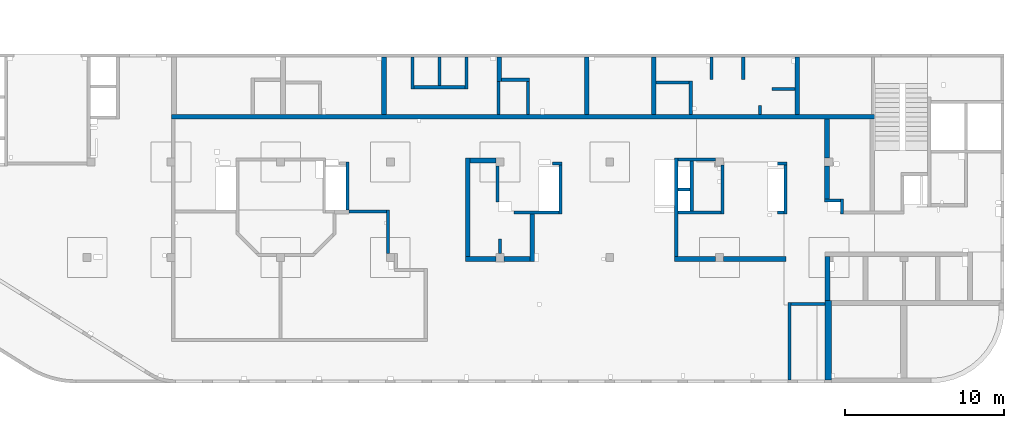
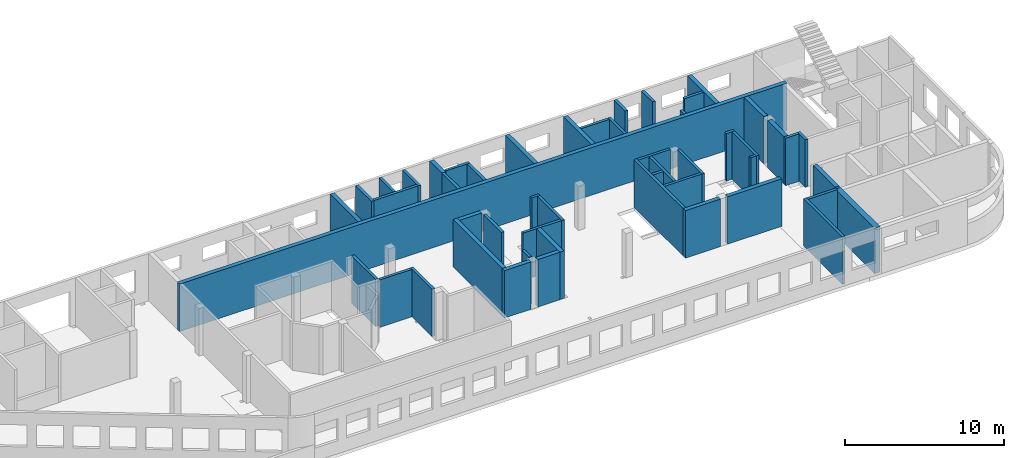
# One storey, part 4 of 10: 51 walls.
"""IFC4 building model written with IfcOpenShell, lengths in millimetres."""

from ifc_helpers import new_model, entity, si_unit, converted_unit, derived_unit, direction, frame, origin, place, context, subcontext, project, spatial, indexed_curve, outline, extrude, material, type_object, element, save


model = new_model("IFC4")

# Units and contexts
model_context = context("Model", 3, precision=0.01, world=origin(), true_north=direction((6.12303176911189e-17, 1.0)))
plan_context = context("Plan", 3, precision=0.01, world=origin(), true_north=direction((6.12303176911189e-17, 1.0)))
body_context = subcontext(model_context, "Body", "Model", "MODEL_VIEW")
ifc_project = project(units=[si_unit("LENGTHUNIT", "METRE", prefix="MILLI"), si_unit("AREAUNIT", "SQUARE_METRE"), si_unit("VOLUMEUNIT", "CUBIC_METRE"), converted_unit("PLANEANGLEUNIT", "DEGREE", entity("IfcRatioMeasure", 0.0174532925199433), si_unit("PLANEANGLEUNIT", "RADIAN"), dimensions=[0, 0, 0, 0, 0, 0, 0]), si_unit("MASSUNIT", "GRAM", prefix="KILO"), derived_unit("MASSDENSITYUNIT", [(si_unit("MASSUNIT", "GRAM", prefix="KILO"), 1), (si_unit("LENGTHUNIT", "METRE"), -3)]), derived_unit("MOMENTOFINERTIAUNIT", [(si_unit("LENGTHUNIT", "METRE"), 4)]), si_unit("TIMEUNIT", "SECOND"), si_unit("FREQUENCYUNIT", "HERTZ"), si_unit("THERMODYNAMICTEMPERATUREUNIT", "DEGREE_CELSIUS"), derived_unit("THERMALTRANSMITTANCEUNIT", [(si_unit("MASSUNIT", "GRAM", prefix="KILO"), 1), (si_unit("THERMODYNAMICTEMPERATUREUNIT", "KELVIN"), -1), (si_unit("TIMEUNIT", "SECOND"), -3)]), derived_unit("VOLUMETRICFLOWRATEUNIT", [(si_unit("LENGTHUNIT", "METRE"), 3), (si_unit("TIMEUNIT", "SECOND"), -1)]), derived_unit("MASSFLOWRATEUNIT", [(si_unit("MASSUNIT", "GRAM", prefix="KILO"), 1), (si_unit("TIMEUNIT", "SECOND"), -1)]), derived_unit("ROTATIONALFREQUENCYUNIT", [(si_unit("TIMEUNIT", "SECOND"), -1)]), si_unit("ELECTRICCURRENTUNIT", "AMPERE"), si_unit("ELECTRICVOLTAGEUNIT", "VOLT"), si_unit("POWERUNIT", "WATT"), si_unit("FORCEUNIT", "NEWTON", prefix="KILO"), si_unit("ILLUMINANCEUNIT", "LUX"), si_unit("LUMINOUSFLUXUNIT", "LUMEN"), si_unit("LUMINOUSINTENSITYUNIT", "CANDELA"), derived_unit("USERDEFINED", [(si_unit("MASSUNIT", "GRAM", prefix="KILO"), -1), (si_unit("LENGTHUNIT", "METRE"), -2), (si_unit("TIMEUNIT", "SECOND"), 3), (si_unit("LUMINOUSFLUXUNIT", "LUMEN"), 1)]), derived_unit("LINEARVELOCITYUNIT", [(si_unit("LENGTHUNIT", "METRE"), 1), (si_unit("TIMEUNIT", "SECOND"), -1)]), si_unit("PRESSUREUNIT", "PASCAL"), derived_unit("USERDEFINED", [(si_unit("LENGTHUNIT", "METRE"), -2), (si_unit("MASSUNIT", "GRAM", prefix="KILO"), 1), (si_unit("TIMEUNIT", "SECOND"), -2)]), derived_unit("LINEARFORCEUNIT", [(si_unit("MASSUNIT", "GRAM", prefix="KILO"), 1), (si_unit("LENGTHUNIT", "METRE"), 1), (si_unit("TIMEUNIT", "SECOND"), -2), (si_unit("LENGTHUNIT", "METRE"), -1)]), derived_unit("PLANARFORCEUNIT", [(si_unit("MASSUNIT", "GRAM", prefix="KILO"), 1), (si_unit("LENGTHUNIT", "METRE"), 1), (si_unit("TIMEUNIT", "SECOND"), -2), (si_unit("LENGTHUNIT", "METRE"), -2)])], contexts=[model_context, plan_context])

# Site, building, storey
site_placement = place(None, origin())
site = spatial("IfcSite", under=ifc_project, at=site_placement, CompositionType="ELEMENT")
building_placement = place(site_placement, origin())
building = spatial("IfcBuilding", under=site, at=building_placement, CompositionType="ELEMENT")
storey_placement = place(building_placement, frame((0.0, 0.0, 4200.0)))
storey = spatial("IfcBuildingStorey", under=building, at=storey_placement, CompositionType="ELEMENT", Elevation=4200.0)

# Walls
ifc_material = material()
wall_type_1 = type_object("IfcWallType", PredefinedType="STANDARD")
wall_1_placement = place(storey_placement, frame((36370.0002685547, 20299.9992263563, -150.0), z_axis=(0.0, 0.0, 1.0), x_axis=(0.0, -1.0, 0.0)))
element("IfcWall", 1, at=wall_1_placement, inside=storey, type_object=wall_type_1, material=ifc_material, PredefinedType="NOTDEFINED", context=body_context, shape_type="SweptSolid", body=[
    extrude(outline(indexed_curve([(2000.00000000011, 99.9999999999993), (-2.37709667564423e-13, 99.9999999999989), (2.37709667564423e-13, -99.9999999999989), (2000.00000000011, -99.9999999999985), (2000.00000000011, 99.9999999999993)], self_intersect=False)), origin(), (0.0, 0.0, 1.0), 3600.0),
])
wall_2_placement = place(storey_placement, frame((38070.0002685547, 20299.9992263563, -150.0), z_axis=(0.0, 0.0, 1.0), x_axis=(0.0, -1.0, 0.0)))
element("IfcWall", 2, at=wall_2_placement, inside=storey, type_object=wall_type_1, material=ifc_material, PredefinedType="NOTDEFINED", context=body_context, shape_type="SweptSolid", body=[
    extrude(outline(indexed_curve([(1800.00000000011, 99.9999999999989), (-2.37709667564423e-13, 99.9999999999989), (2.37709667564423e-13, -99.9999999999989), (1800.00000000011, -99.999999999999), (1800.00000000011, 99.9999999999989)], self_intersect=False)), origin(), (0.0, 0.0, 1.0), 3600.0),
])
wall_3_placement = place(storey_placement, frame((39770.0002685547, 20299.9992263563, -150.0), z_axis=(0.0, 0.0, 1.0), x_axis=(0.0, -1.0, 0.0)))
element("IfcWall", 3, at=wall_3_placement, inside=storey, type_object=wall_type_1, material=ifc_material, PredefinedType="NOTDEFINED", context=body_context, shape_type="SweptSolid", body=[
    extrude(outline(indexed_curve([(2000.00000000011, 99.9999999999993), (-2.37709667564433e-13, 100.000000000003), (2.37709667564433e-13, -100.000000000003), (2000.00000000011, -100.000000000007), (2000.00000000011, 99.9999999999993)], self_intersect=False)), origin(), (0.0, 0.0, 1.0), 3600.0),
])
wall_4_placement = place(storey_placement, frame((36470.0002685547, 18399.9992263562, -150.0)))
element("IfcWall", 4, at=wall_4_placement, inside=storey, type_object=wall_type_1, material=ifc_material, PredefinedType="NOTDEFINED", context=body_context, shape_type="SweptSolid", body=[
    extrude(outline(indexed_curve([(3200.00000000001, 99.9999999999986), (-3.28141554332843e-13, 99.9999999999989), (3.28141554332843e-13, -99.9999999999989), (3200.00000000001, -99.9999999999992), (3200.00000000001, 99.9999999999986)], self_intersect=False)), origin(), (0.0, 0.0, 1.0), 3600.0),
])
wall_5_placement = place(storey_placement, frame((41970.0002685547, 18879.9992263561, -150.0)))
element("IfcWall", 5, at=wall_5_placement, inside=storey, type_object=wall_type_1, material=ifc_material, PredefinedType="NOTDEFINED", context=body_context, shape_type="SweptSolid", body=[
    extrude(outline(indexed_curve([(1749.99999999999, 99.9999999999981), (-3.22176291013974e-13, 99.9999999999989), (3.22176291013974e-13, -99.9999999999989), (1749.99999999999, -99.9999999999998), (1749.99999999999, 99.9999999999981)], self_intersect=False)), origin(), (0.0, 0.0, 1.0), 3650.0),
])
wall_6_placement = place(storey_placement, frame((41770.0002685547, 18779.999226356, -150.0), z_axis=(0.0, 0.0, 1.0), x_axis=(0.0, -1.0, 0.0)))
element("IfcWall", 6, at=wall_6_placement, inside=storey, type_object=wall_type_1, material=ifc_material, PredefinedType="NOTDEFINED", context=body_context, shape_type="SweptSolid", body=[
    extrude(outline(indexed_curve([(2080.0, 100.000000000003), (0.0, 100.000000000003), (0.0, -100.000000000003), (2080.0, -100.000000000003), (2080.0, 100.000000000003)], self_intersect=False)), origin(), (0.0, 0.0, 1.0), 3600.0),
])
wall_7_placement = place(storey_placement, frame((43620.0002685547, 16699.999226356, -150.0), z_axis=(0.0, 0.0, 1.0), x_axis=(0.0, 1.0, 0.0)))
element("IfcWall", 7, at=wall_7_placement, inside=storey, type_object=wall_type_1, material=ifc_material, PredefinedType="NOTDEFINED", context=body_context, shape_type="SweptSolid", body=[
    extrude(outline(indexed_curve([(2080.0, 100.000000000003), (0.0, 100.000000000003), (0.0, -100.000000000003), (2080.0, -100.000000000003), (2080.0, 100.000000000003)], self_intersect=False)), origin(), (0.0, 0.0, 1.0), 3650.0),
])
wall_8_placement = place(storey_placement, frame((55170.0002685547, 20299.9992263562, -150.0), z_axis=(0.0, 0.0, 1.0), x_axis=(0.0, -1.0, 0.0)))
element("IfcWall", 8, at=wall_8_placement, inside=storey, type_object=wall_type_1, material=ifc_material, PredefinedType="NOTDEFINED", context=body_context, shape_type="SweptSolid", body=[
    extrude(outline(indexed_curve([(1400.00000000018, 100.000000000003), (0.0, 100.000000000003), (0.0, -100.000000000003), (1400.00000000018, -100.000000000003), (1400.00000000018, 100.000000000003)], self_intersect=False)), origin(), (0.0, 0.0, 1.0), 3600.0),
])
wall_9_placement = place(storey_placement, frame((57170.0002685547, 20299.9992263562, -150.0), z_axis=(0.0, 0.0, 1.0), x_axis=(0.0, -1.0, 0.0)))
element("IfcWall", 9, at=wall_9_placement, inside=storey, type_object=wall_type_1, material=ifc_material, PredefinedType="NOTDEFINED", context=body_context, shape_type="SweptSolid", body=[
    extrude(outline(indexed_curve([(1400.00000000017, 100.000000000003), (0.0, 100.000000000003), (0.0, -100.000000000003), (1400.00000000017, -100.000000000003), (1400.00000000017, 100.000000000003)], self_intersect=False)), origin(), (0.0, 0.0, 1.0), 3600.0),
])
wall_10_placement = place(storey_placement, frame((53870.0002685547, 16699.999226356, -150.0), z_axis=(0.0, 0.0, 1.0), x_axis=(0.0, 1.0, 0.0)))
element("IfcWall", 10, at=wall_10_placement, inside=storey, type_object=wall_type_1, material=ifc_material, PredefinedType="NOTDEFINED", context=body_context, shape_type="SweptSolid", body=[
    extrude(outline(indexed_curve([(2100.0, 100.000000000003), (0.0, 100.000000000003), (0.0, -100.000000000003), (2100.0, -100.000000000003), (2100.0, 100.000000000003)], self_intersect=False)), origin(), (0.0, 0.0, 1.0), 3600.0),
])
wall_11_placement = place(storey_placement, frame((53770.0002685547, 18699.999226356, -150.0), z_axis=(0.0, 0.0, 1.0), x_axis=(-1.0, 0.0, 0.0)))
element("IfcWall", 11, at=wall_11_placement, inside=storey, type_object=wall_type_1, material=ifc_material, PredefinedType="NOTDEFINED", context=body_context, shape_type="SweptSolid", body=[
    extrude(outline(indexed_curve([(2079.99999999999, 99.9999999999984), (-2.84965034025891e-13, 99.9999999999989), (2.84965034025891e-13, -99.9999999999989), (2080.0, -99.9999999999995), (2079.99999999999, 99.9999999999984)], self_intersect=False)), origin(), (0.0, 0.0, 1.0), 3600.0),
])
wall_12_placement = place(storey_placement, frame((58220.0002685547, 16699.999226356, -150.0), z_axis=(0.0, 0.0, 1.0), x_axis=(0.0, 1.0, 0.0)))
element("IfcWall", 12, at=wall_12_placement, inside=storey, type_object=wall_type_1, material=ifc_material, PredefinedType="NOTDEFINED", context=body_context, shape_type="SweptSolid", body=[
    extrude(outline(indexed_curve([(550.000000000001, 100.000000000003), (0.0, 100.000000000003), (0.0, -100.000000000003), (550.000000000001, -100.000000000003), (550.000000000001, 100.000000000003)], self_intersect=False)), origin(), (0.0, 0.0, 1.0), 3600.0),
])
wall_13_placement = place(storey_placement, frame((60420.0002685547, 18299.999226356, -150.0), z_axis=(0.0, 0.0, 1.0), x_axis=(-1.0, 0.0, 0.0)))
element("IfcWall", 13, at=wall_13_placement, inside=storey, type_object=wall_type_1, material=ifc_material, PredefinedType="NOTDEFINED", context=body_context, shape_type="SweptSolid", body=[
    extrude(outline(indexed_curve([(1430.0, 99.9999999999994), (-3.38034999930937e-13, 99.9999999999989), (3.38034999930937e-13, -99.9999999999989), (1430.0, -99.9999999999984), (1430.0, 99.9999999999994)], self_intersect=False)), origin(), (0.0, 0.0, 1.0), 3600.0),
])
wall_14_placement = place(storey_placement, frame((62295.0002685547, 11285.0, -150.0)))
element("IfcWall", 14, at=wall_14_placement, inside=storey, type_object=wall_type_1, material=ifc_material, PredefinedType="NOTDEFINED", context=body_context, shape_type="SweptSolid", body=[
    extrude(outline(indexed_curve([(990.0, 99.9999999999984), (-3.8634469513083e-13, 99.9999999999989), (3.8634469513083e-13, -99.9999999999989), (990.000000000001, -99.9999999999994), (990.0, 99.9999999999984)], self_intersect=False)), origin(), (0.0, 0.0, 1.0), 3650.0),
])
wall_15_placement = place(storey_placement, frame((63385.0002685547, 11385.0, -150.0), z_axis=(0.0, 0.0, 1.0), x_axis=(0.0, -1.0, 0.0)))
element("IfcWall", 15, at=wall_15_placement, inside=storey, type_object=wall_type_1, material=ifc_material, PredefinedType="NOTDEFINED", context=body_context, shape_type="SweptSolid", body=[
    extrude(outline(indexed_curve([(960.0, 100.000000000003), (0.0, 100.000000000003), (0.0, -100.000000000003), (960.0, -100.000000000003), (960.0, 100.000000000003)], self_intersect=False)), origin(), (0.0, 0.0, 1.0), 3650.0),
])
wall_16_placement = place(storey_placement, frame((59330.0002685547, 13599.9992263562, -150.0)))
element("IfcWall", 16, at=wall_16_placement, inside=storey, type_object=wall_type_1, material=ifc_material, PredefinedType="NOTDEFINED", context=body_context, shape_type="SweptSolid", body=[
    extrude(outline(indexed_curve([(600.000000000002, 99.9999999999989), (-3.60955709766126e-13, 99.9999999999989), (3.60955709766126e-13, -99.9999999999989), (600.000000000003, -99.9999999999989), (600.000000000002, 99.9999999999989)], self_intersect=False)), origin(), (0.0, 0.0, 1.0), 3650.0),
])
wall_17_placement = place(storey_placement, frame((59830.0002685547, 13499.9992263562, -150.0), z_axis=(0.0, 0.0, 1.0), x_axis=(0.0, -1.0, 0.0)))
element("IfcWall", 17, at=wall_17_placement, inside=storey, type_object=wall_type_1, material=ifc_material, PredefinedType="NOTDEFINED", context=body_context, shape_type="SweptSolid", body=[
    extrude(outline(indexed_curve([(3075.00000000016, 100.000000000003), (-2.64517161355328e-13, 100.000000000003), (2.64517161355328e-13, -100.000000000003), (3075.00000000016, -100.000000000004), (3075.00000000016, 100.000000000003)], self_intersect=False)), origin(), (0.0, 0.0, 1.0), 3650.0),
])
wall_18_placement = place(storey_placement, frame((59730.0002685547, 10524.999226356, -150.0), z_axis=(0.0, 0.0, 1.0), x_axis=(-1.0, 0.0, 0.0)))
element("IfcWall", 18, at=wall_18_placement, inside=storey, type_object=wall_type_1, material=ifc_material, PredefinedType="NOTDEFINED", context=body_context, shape_type="SweptSolid", body=[
    extrude(outline(indexed_curve([(400.000000000013, 99.9999999999982), (-3.6095570976612e-13, 99.9999999999989), (3.6095570976612e-13, -99.9999999999989), (400.000000000013, -99.9999999999996), (400.000000000013, 99.9999999999982)], self_intersect=False)), origin(), (0.0, 0.0, 1.0), 3650.0),
])
wall_19_placement = place(storey_placement, frame((60070.0002685546, -0.000773643870423513, -150.0), z_axis=(0.0, 0.0, 1.0), x_axis=(0.0, 1.0, 0.0)))
element("IfcWall", 19, at=wall_19_placement, inside=storey, type_object=wall_type_1, material=ifc_material, PredefinedType="NOTDEFINED", context=body_context, shape_type="SweptSolid", body=[
    extrude(outline(indexed_curve([(4875.0, 100.000000000009), (-1.63282015819024e-14, 100.000000000003), (1.63282015819024e-14, -100.000000000003), (4875.0, -99.9999999999979), (4875.0, 100.000000000009)], self_intersect=False)), origin(), (0.0, 0.0, 1.0), 3650.0),
])
wall_20_placement = place(storey_placement, frame((62320.0002685546, 4774.99922635612, -150.0), z_axis=(0.0, 0.0, 1.0), x_axis=(-1.0, 0.0, 0.0)))
element("IfcWall", 20, at=wall_20_placement, inside=storey, type_object=wall_type_1, material=ifc_material, PredefinedType="NOTDEFINED", context=body_context, shape_type="SweptSolid", body=[
    extrude(outline(indexed_curve([(2150.0, 99.9999999999995), (-3.2985095535215e-13, 100.0), (3.2985095535215e-13, -100.0), (2150.0, -100.000000000001), (2150.0, 99.9999999999995)], self_intersect=False)), origin(), (0.0, 0.0, 1.0), 3650.0),
])
wall_21_placement = place(storey_placement, frame((52950.0002685547, 7749.99922635622, -150.0), z_axis=(0.0, 0.0, 1.0), x_axis=(0.0, 1.0, 0.0)))
element("IfcWall", 21, at=wall_21_placement, inside=storey, type_object=wall_type_1, material=ifc_material, PredefinedType="NOTDEFINED", context=body_context, shape_type="SweptSolid", body=[
    extrude(outline(indexed_curve([(6200.00000000002, 100.000000000003), (0.0, 100.000000000003), (0.0, -100.000000000003), (6200.00000000002, -100.000000000003), (6200.00000000002, 100.000000000003)], self_intersect=False)), origin(), (0.0, 0.0, 1.0), 3650.0),
])
wall_22_placement = place(storey_placement, frame((55870.0002685546, 13499.9992263562, -150.0), z_axis=(0.0, 0.0, 1.0), x_axis=(0.0, -1.0, 0.0)))
element("IfcWall", 22, at=wall_22_placement, inside=storey, type_object=wall_type_1, material=ifc_material, PredefinedType="NOTDEFINED", context=body_context, shape_type="SweptSolid", body=[
    extrude(outline(indexed_curve([(3074.99999999999, 100.000000000003), (-2.72033140241541e-13, 100.000000000003), (2.72033140241541e-13, -100.000000000003), (3074.99999999999, -100.000000000004), (3074.99999999999, 100.000000000003)], self_intersect=False)), origin(), (0.0, 0.0, 1.0), 3650.0),
])
wall_23_placement = place(storey_placement, frame((55420.0002685547, 13849.9992263562, -150.0), z_axis=(0.0, 0.0, 1.0), x_axis=(-1.0, 0.0, 0.0)))
element("IfcWall", 23, at=wall_23_placement, inside=storey, type_object=wall_type_1, material=ifc_material, PredefinedType="NOTDEFINED", context=body_context, shape_type="SweptSolid", body=[
    extrude(outline(indexed_curve([(2370.00000000002, 99.9999999999998), (-3.12103746660829e-13, 99.9999999999989), (3.12103746660829e-13, -99.9999999999989), (2370.00000000002, -99.999999999998), (2370.00000000002, 99.9999999999998)], self_intersect=False)), origin(), (0.0, 0.0, 1.0), 3650.0),
])
wall_24_placement = place(storey_placement, frame((55770.0002685546, 10524.9992263562, -150.0), z_axis=(0.0, 0.0, 1.0), x_axis=(-1.0, 0.0, 0.0)))
element("IfcWall", 24, at=wall_24_placement, inside=storey, type_object=wall_type_1, material=ifc_material, PredefinedType="NOTDEFINED", context=body_context, shape_type="SweptSolid", body=[
    extrude(outline(indexed_curve([(2719.99999999999, 100.000000000001), (-3.01844495971679e-13, 100.000000000001), (3.01844495971679e-13, -100.000000000001), (2719.99999999999, -100.000000000002), (2719.99999999999, 100.000000000001)], self_intersect=False)), origin(), (0.0, 0.0, 1.0), 3650.0),
])
wall_25_placement = place(storey_placement, frame((53050.0002685546, 11974.9992263562, -150.0)))
element("IfcWall", 25, at=wall_25_placement, inside=storey, type_object=wall_type_1, material=ifc_material, PredefinedType="NOTDEFINED", context=body_context, shape_type="SweptSolid", body=[
    extrude(outline(indexed_curve([(780.000000000004, 99.9999999999993), (-3.27472843447334e-13, 99.9999999999989), (3.27472843447334e-13, -99.9999999999989), (780.000000000005, -99.9999999999985), (780.000000000004, 99.9999999999993)], self_intersect=False)), origin(), (0.0, 0.0, 1.0), 3650.0),
])
wall_26_placement = place(storey_placement, frame((53930.0002685547, 10624.9992263562, -150.0), z_axis=(0.0, 0.0, 1.0), x_axis=(0.0, 1.0, 0.0)))
element("IfcWall", 26, at=wall_26_placement, inside=storey, type_object=wall_type_1, material=ifc_material, PredefinedType="NOTDEFINED", context=body_context, shape_type="SweptSolid", body=[
    extrude(outline(indexed_curve([(3125.00000000001, 100.000000000003), (0.0, 100.000000000003), (0.0, -100.000000000003), (3125.00000000001, -100.000000000003), (3125.00000000001, 100.000000000003)], self_intersect=False)), origin(), (0.0, 0.0, 1.0), 3650.0),
])
wall_27_placement = place(storey_placement, frame((45170.0002685547, 13599.9992263561, -150.0)))
element("IfcWall", 27, at=wall_27_placement, inside=storey, type_object=wall_type_1, material=ifc_material, PredefinedType="NOTDEFINED", context=body_context, shape_type="SweptSolid", body=[
    extrude(outline(indexed_curve([(600.000000000002, 99.9999999999989), (-3.60955709766126e-13, 99.9999999999989), (3.60955709766126e-13, -99.9999999999989), (600.000000000003, -99.9999999999989), (600.000000000002, 99.9999999999989)], self_intersect=False)), origin(), (0.0, 0.0, 1.0), 3650.0),
])
wall_28_placement = place(storey_placement, frame((45670.0002685547, 13499.9992263561, -150.0), z_axis=(0.0, 0.0, 1.0), x_axis=(0.0, -1.0, 0.0)))
element("IfcWall", 28, at=wall_28_placement, inside=storey, type_object=wall_type_1, material=ifc_material, PredefinedType="NOTDEFINED", context=body_context, shape_type="SweptSolid", body=[
    extrude(outline(indexed_curve([(3075.0, 100.000000000003), (-2.64517161355341e-13, 100.000000000003), (2.64517161355341e-13, -100.000000000003), (3075.0, -100.000000000004), (3075.0, 100.000000000003)], self_intersect=False)), origin(), (0.0, 0.0, 1.0), 3650.0),
])
wall_29_placement = place(storey_placement, frame((45570.0002685547, 10524.9992263561, -150.0), z_axis=(0.0, 0.0, 1.0), x_axis=(-1.0, 0.0, 0.0)))
element("IfcWall", 29, at=wall_29_placement, inside=storey, type_object=wall_type_1, material=ifc_material, PredefinedType="NOTDEFINED", context=body_context, shape_type="SweptSolid", body=[
    extrude(outline(indexed_curve([(2825.0, 99.9999999999986), (-2.21173189477145e-12, 99.9999999999989), (2.21173189477145e-12, -99.9999999999989), (2825.0, -99.9999999999992), (2825.0, 99.9999999999986)], self_intersect=False)), origin(), (0.0, 0.0, 1.0), 3650.0),
])
wall_30_placement = place(storey_placement, frame((41720.0002685547, 13449.9992263563, -150.0), z_axis=(0.0, 0.0, 1.0), x_axis=(0.0, -1.0, 0.0)))
element("IfcWall", 30, at=wall_30_placement, inside=storey, type_object=wall_type_1, material=ifc_material, PredefinedType="NOTDEFINED", context=body_context, shape_type="SweptSolid", body=[
    extrude(outline(indexed_curve([(2265.0000000001, 100.000000000003), (0.0, 100.000000000003), (0.0, -100.000000000003), (2265.0000000001, -100.000000000003), (2265.0000000001, 100.000000000003)], self_intersect=False)), origin(), (0.0, 0.0, 1.0), 3650.0),
])
wall_31_placement = place(storey_placement, frame((34820.0002685546, 7949.99922635628, -150.0), z_axis=(0.0, 0.0, 1.0), x_axis=(0.0, 1.0, 0.0)))
element("IfcWall", 31, at=wall_31_placement, inside=storey, type_object=wall_type_1, material=ifc_material, PredefinedType="NOTDEFINED", context=body_context, shape_type="SweptSolid", body=[
    extrude(outline(indexed_curve([(2740.0, 99.999999999999), (-1.61924056717522e-13, 99.9999999999989), (1.61924056717522e-13, -99.9999999999989), (2740.0, -99.9999999999988), (2740.0, 99.999999999999)], self_intersect=False)), origin(), (0.0, 0.0, 1.0), 3650.0),
])
wall_32_placement = place(storey_placement, frame((34720.0002685546, 10589.9992263563, -150.0), z_axis=(0.0, 0.0, 1.0), x_axis=(-1.0, 0.0, 0.0)))
element("IfcWall", 32, at=wall_32_placement, inside=storey, type_object=wall_type_1, material=ifc_material, PredefinedType="NOTDEFINED", context=body_context, shape_type="SweptSolid", body=[
    extrude(outline(indexed_curve([(2349.99999999999, 100.000000000002), (-5.70598363989661e-13, 100.000000000001), (5.70598363989661e-13, -100.000000000001), (2349.99999999999, -100.000000000001), (2349.99999999999, 100.000000000002)], self_intersect=False)), origin(), (0.0, 0.0, 1.0), 3650.0),
])
wall_33_placement = place(storey_placement, frame((32270.0002685546, 10689.9992263563, -150.0), z_axis=(0.0, 0.0, 1.0), x_axis=(0.0, 1.0, 0.0)))
element("IfcWall", 33, at=wall_33_placement, inside=storey, type_object=wall_type_1, material=ifc_material, PredefinedType="NOTDEFINED", context=body_context, shape_type="SweptSolid", body=[
    extrude(outline(indexed_curve([(3009.99999999989, 99.9999999999989), (-1.43902608544639e-13, 99.9999999999989), (1.43902608544639e-13, -99.9999999999989), (3009.99999999989, -99.9999999999989), (3009.99999999989, 99.9999999999989)], self_intersect=False)), origin(), (0.0, 0.0, 1.0), 3650.0),
])
wall_34_placement = place(storey_placement, frame((41870.0, 7949.99922635626, -150.0), z_axis=(0.0, 0.0, 1.0), x_axis=(0.0, 1.0, 0.0)))
element("IfcWall", 34, at=wall_34_placement, inside=storey, type_object=wall_type_1, material=ifc_material, PredefinedType="NOTDEFINED", context=body_context, shape_type="SweptSolid", body=[
    extrude(outline(indexed_curve([(900.00077364374, 100.000000000003), (0.0, 100.000000000003), (0.0, -100.000000000003), (900.00077364374, -100.000000000003), (900.00077364374, 100.000000000003)], self_intersect=False)), origin(), (0.0, 0.0, 1.0), 3650.0),
])
wall_type_2 = type_object("IfcWallType", PredefinedType="STANDARD")
wall_35_placement = place(storey_placement, frame((21220.0002685547, 16549.9992263561, -150.0)))
element("IfcWall", 35, at=wall_35_placement, inside=storey, type_object=wall_type_2, material=ifc_material, PredefinedType="NOTDEFINED", context=body_context, shape_type="SweptSolid", body=[
    extrude(outline(indexed_curve([(44210.0, 150.000000000002), (-5.2028848286608e-13, 150.000000000001), (5.2028848286608e-13, -150.000000000001), (44210.0, -149.999999999999), (44210.0, 150.000000000002)], self_intersect=False)), origin(), (0.0, 0.0, 1.0), 3650.0),
])
wall_36_placement = place(storey_placement, frame((34570.0002685547, 20299.9992263563, -150.0), z_axis=(0.0, 0.0, 1.0), x_axis=(0.0, -1.0, 0.0)))
element("IfcWall", 36, at=wall_36_placement, inside=storey, type_object=wall_type_2, material=ifc_material, PredefinedType="NOTDEFINED", context=body_context, shape_type="SweptSolid", body=[
    extrude(outline(indexed_curve([(3600.00000000024, 150.000000000001), (-1.806020255871e-13, 150.000000000001), (1.806020255871e-13, -150.000000000001), (3600.00000000024, -150.000000000001), (3600.00000000024, 150.000000000001)], self_intersect=False)), origin(), (0.0, 0.0, 1.0), 3600.0),
])
wall_37_placement = place(storey_placement, frame((41820.0002685547, 20299.9992263563, -150.0), z_axis=(0.0, 0.0, 1.0), x_axis=(0.0, -1.0, 0.0)))
element("IfcWall", 37, at=wall_37_placement, inside=storey, type_object=wall_type_2, material=ifc_material, PredefinedType="NOTDEFINED", context=body_context, shape_type="SweptSolid", body=[
    extrude(outline(indexed_curve([(1520.00000000024, 150.000000000001), (0.0, 150.000000000001), (0.0, -150.000000000001), (1520.00000000024, -150.000000000001), (1520.00000000024, 150.000000000001)], self_intersect=False)), origin(), (0.0, 0.0, 1.0), 3600.0),
])
wall_38_placement = place(storey_placement, frame((47320.0002685547, 20299.9992263563, -150.0), z_axis=(0.0, 0.0, 1.0), x_axis=(0.0, -1.0, 0.0)))
element("IfcWall", 38, at=wall_38_placement, inside=storey, type_object=wall_type_2, material=ifc_material, PredefinedType="NOTDEFINED", context=body_context, shape_type="SweptSolid", body=[
    extrude(outline(indexed_curve([(3600.00000000024, 150.000000000001), (-3.60955709766122e-13, 150.000000000001), (3.60955709766122e-13, -150.000000000001), (3600.00000000024, -150.000000000001), (3600.00000000024, 150.000000000001)], self_intersect=False)), origin(), (0.0, 0.0, 1.0), 3650.0),
])
wall_39_placement = place(storey_placement, frame((51540.0002685547, 20299.9992263563, -150.0), z_axis=(0.0, 0.0, 1.0), x_axis=(0.0, -1.0, 0.0)))
element("IfcWall", 39, at=wall_39_placement, inside=storey, type_object=wall_type_2, material=ifc_material, PredefinedType="NOTDEFINED", context=body_context, shape_type="SweptSolid", body=[
    extrude(outline(indexed_curve([(3600.00000000024, 150.000000000001), (-3.60955709766122e-13, 150.000000000001), (3.60955709766122e-13, -150.000000000001), (3600.00000000024, -150.000000000001), (3600.00000000024, 150.000000000001)], self_intersect=False)), origin(), (0.0, 0.0, 1.0), 3600.0),
])
wall_40_placement = place(storey_placement, frame((60570.0002685547, 20299.9992263562, -150.0), z_axis=(0.0, 0.0, 1.0), x_axis=(0.0, -1.0, 0.0)))
element("IfcWall", 40, at=wall_40_placement, inside=storey, type_object=wall_type_2, material=ifc_material, PredefinedType="NOTDEFINED", context=body_context, shape_type="SweptSolid", body=[
    extrude(outline(indexed_curve([(3600.00000000024, 150.0), (-3.33189885937964e-13, 150.000000000001), (3.33189885937964e-13, -150.000000000001), (3600.00000000024, -150.000000000001), (3600.00000000024, 150.0)], self_intersect=False)), origin(), (0.0, 0.0, 1.0), 3600.0),
])
wall_41_placement = place(storey_placement, frame((62445.0002685547, 13449.9992263562, -150.0), z_axis=(0.0, 0.0, 1.0), x_axis=(0.0, -1.0, 0.0)))
element("IfcWall", 41, at=wall_41_placement, inside=storey, type_object=wall_type_2, material=ifc_material, PredefinedType="NOTDEFINED", context=body_context, shape_type="SweptSolid", body=[
    extrude(outline(indexed_curve([(2064.99922635619, 149.999999999999), (1.01016495972246e-12, 150.000000000001), (-1.01016495972246e-12, -150.000000000001), (2064.99922635619, -150.000000000002), (2064.99922635619, 149.999999999999)], self_intersect=False)), origin(), (0.0, 0.0, 1.0), 3650.0),
])
wall_42_placement = place(storey_placement, frame((62445.0002685547, 13949.9992263562, -150.0), z_axis=(0.0, 0.0, 1.0), x_axis=(0.0, 1.0, 0.0)))
element("IfcWall", 42, at=wall_42_placement, inside=storey, type_object=wall_type_2, material=ifc_material, PredefinedType="NOTDEFINED", context=body_context, shape_type="SweptSolid", body=[
    extrude(outline(indexed_curve([(2449.99999999978, 150.000000000001), (0.0, 150.000000000001), (0.0, -150.000000000001), (2449.99999999978, -150.000000000001), (2449.99999999978, 150.000000000001)], self_intersect=False)), origin(), (0.0, 0.0, 1.0), 3650.0),
])
wall_43_placement = place(storey_placement, frame((55420.0002685547, 7599.99922635621, -150.0), z_axis=(0.0, 0.0, 1.0), x_axis=(-1.0, 0.0, 0.0)))
element("IfcWall", 43, at=wall_43_placement, inside=storey, type_object=wall_type_2, material=ifc_material, PredefinedType="NOTDEFINED", context=body_context, shape_type="SweptSolid", body=[
    extrude(outline(indexed_curve([(2570.0, 150.0), (-3.74838621680215e-13, 150.000000000001), (3.74838621680215e-13, -150.000000000001), (2570.00000000001, -150.000000000001), (2570.0, 150.0)], self_intersect=False)), origin(), (0.0, 0.0, 1.0), 3650.0),
])
wall_44_placement = place(storey_placement, frame((55920.0002685547, 7599.99922635621, -150.0)))
element("IfcWall", 44, at=wall_44_placement, inside=storey, type_object=wall_type_2, material=ifc_material, PredefinedType="NOTDEFINED", context=body_context, shape_type="SweptSolid", body=[
    extrude(outline(indexed_curve([(3949.99999999999, 150.0), (-4.8342864025165e-13, 150.000000000001), (4.8342864025165e-13, -150.000000000001), (3949.99999999999, -150.000000000001), (3949.99999999999, 150.0)], self_intersect=False)), origin(), (0.0, 0.0, 1.0), 3650.0),
])
wall_45_placement = place(storey_placement, frame((43895.0002685547, 10424.9992263562, -150.0), z_axis=(0.0, 0.0, 1.0), x_axis=(0.0, -1.0, 0.0)))
element("IfcWall", 45, at=wall_45_placement, inside=storey, type_object=wall_type_2, material=ifc_material, PredefinedType="NOTDEFINED", context=body_context, shape_type="SweptSolid", body=[
    extrude(outline(indexed_curve([(2975.00000000003, 150.000000000001), (7.74195519671281e-13, 150.000000000001), (-7.74195519671281e-13, -150.000000000001), (2975.00000000003, -150.0), (2975.00000000003, 150.000000000001)], self_intersect=False)), origin(), (0.0, 0.0, 1.0), 3650.0),
])
wall_46_placement = place(storey_placement, frame((42120.0002685547, 7599.99922635626, -150.0)))
element("IfcWall", 46, at=wall_46_placement, inside=storey, type_object=wall_type_2, material=ifc_material, PredefinedType="NOTDEFINED", context=body_context, shape_type="SweptSolid", body=[
    extrude(outline(indexed_curve([(1624.9999999999, 150.0), (-4.19915577515643e-13, 150.000000000001), (4.19915577515643e-13, -150.000000000001), (1624.9999999999, -150.000000000001), (1624.9999999999, 150.0)], self_intersect=False)), origin(), (0.0, 0.0, 1.0), 3650.0),
])
wall_47_placement = place(storey_placement, frame((41620.0002685546, 7599.99922635626, -150.0), z_axis=(0.0, 0.0, 1.0), x_axis=(-1.0, 0.0, 0.0)))
element("IfcWall", 47, at=wall_47_placement, inside=storey, type_object=wall_type_2, material=ifc_material, PredefinedType="NOTDEFINED", context=body_context, shape_type="SweptSolid", body=[
    extrude(outline(indexed_curve([(1925.0, 150.0), (3.18790998622199e-13, 150.000000000001), (-3.18790998622199e-13, -150.000000000001), (1925.0, -150.000000000001), (1925.0, 150.0)], self_intersect=False)), origin(), (0.0, 0.0, 1.0), 3650.0),
])
wall_48_placement = place(storey_placement, frame((39845.0002685547, 7749.99922635614, -150.0), z_axis=(0.0, 0.0, 1.0), x_axis=(0.0, 1.0, 0.0)))
element("IfcWall", 48, at=wall_48_placement, inside=storey, type_object=wall_type_2, material=ifc_material, PredefinedType="NOTDEFINED", context=body_context, shape_type="SweptSolid", body=[
    extrude(outline(indexed_curve([(6200.00000000013, 150.000000000001), (0.0, 150.000000000001), (0.0, -150.000000000001), (6200.00000000013, -150.000000000001), (6200.00000000013, 150.000000000001)], self_intersect=False)), origin(), (0.0, 0.0, 1.0), 3650.0),
])
wall_49_placement = place(storey_placement, frame((41620.0002685547, 13799.9992263563, -150.0), z_axis=(0.0, 0.0, 1.0), x_axis=(-1.0, 0.0, 0.0)))
element("IfcWall", 49, at=wall_49_placement, inside=storey, type_object=wall_type_2, material=ifc_material, PredefinedType="NOTDEFINED", context=body_context, shape_type="SweptSolid", body=[
    extrude(outline(indexed_curve([(1625.0, 150.000000000001), (-4.44253181250625e-13, 150.000000000001), (4.44253181250625e-13, -150.000000000001), (1625.0, -150.0), (1625.0, 150.000000000001)], self_intersect=False)), origin(), (0.0, 0.0, 1.0), 3650.0),
])
wall_50_placement = place(storey_placement, frame((62470.0002685546, 4674.99922635612, -150.0), z_axis=(0.0, 0.0, 1.0), x_axis=(0.0, 1.0, 0.0)))
element("IfcWall", 50, at=wall_50_placement, inside=storey, type_object=wall_type_2, material=ifc_material, PredefinedType="NOTDEFINED", context=body_context, shape_type="SweptSolid", body=[
    extrude(outline(indexed_curve([(3074.99999999989, -150.000000000001), (3074.99999999989, 150.000000000001), (300.000000000001, 150.000000000001), (300.0, -150.000000000001), (2775.00000000007, -150.000000000001), (3074.99999999989, -150.000000000001)], self_intersect=False)), origin(), (0.0, 0.0, 1.0), 3650.0),
])
wall_type_3 = type_object("IfcWallType", PredefinedType="STANDARD")
wall_51_placement = place(storey_placement, frame((62520.0002685546, -0.000773643878460417, -150.0), z_axis=(0.0, 0.0, 1.0), x_axis=(0.0, 1.0, 0.0)))
element("IfcWall", 51, at=wall_51_placement, inside=storey, type_object=wall_type_3, material=ifc_material, PredefinedType="NOTDEFINED", context=body_context, shape_type="SweptSolid", body=[
    extrude(outline(indexed_curve([(4975.0, 199.999999999999), (-6.47205422223699e-15, 199.999999999998), (6.47205422223699e-15, -199.999999999998), (4975.0, -199.999999999997), (4975.0, 199.999999999999)], self_intersect=False)), origin(), (0.0, 0.0, 1.0), 3500.0),
])

save(model, "model.ifc")
